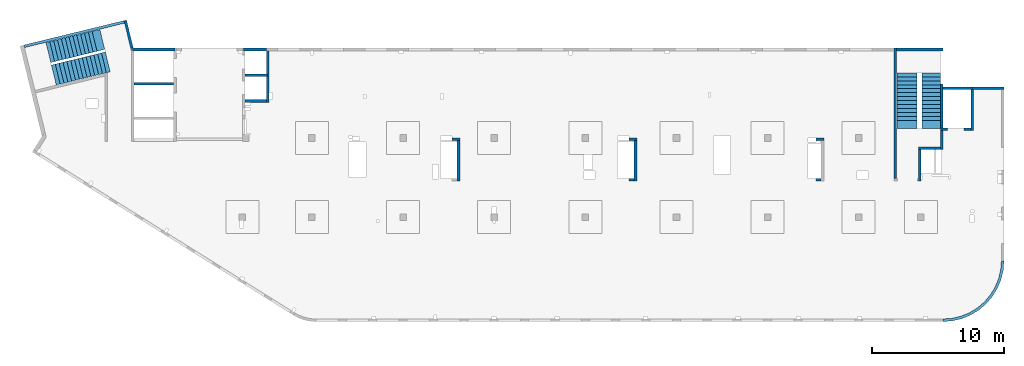
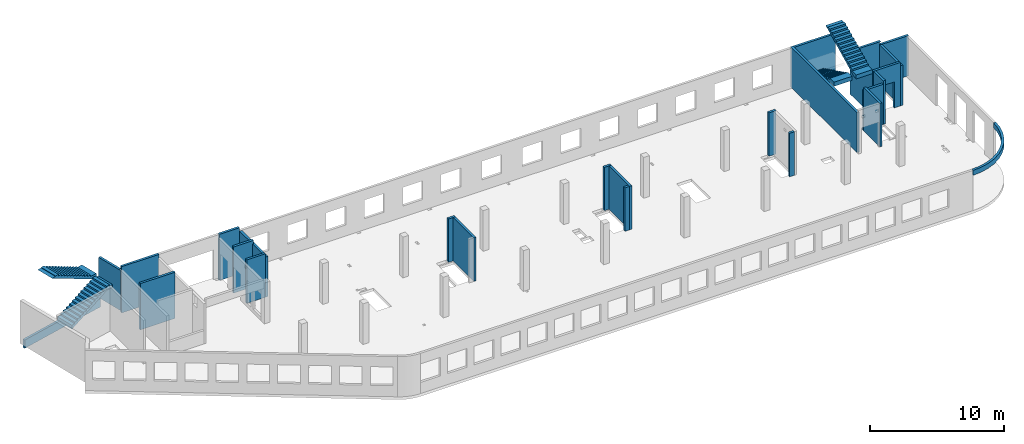
# One storey, part 3 of 6: 26 walls, 4 stairs, 1 opening.
"""IFC4 building model written with IfcOpenShell, lengths in millimetres."""

from ifc_helpers import new_model, entity, si_unit, converted_unit, derived_unit, direction, frame, origin, place, context, subcontext, project, spatial, indexed_curve, outline, extrude, polygons, material, type_object, element, save


model = new_model("IFC4")

# Units and contexts
model_context = context("Model", 3, precision=0.01, world=origin(), true_north=direction((6.12303176911189e-17, 1.0)))
plan_context = context("Plan", 3, precision=0.01, world=origin(), true_north=direction((6.12303176911189e-17, 1.0)))
body_context = subcontext(model_context, "Body", "Model", "MODEL_VIEW")
ifc_project = project(units=[si_unit("LENGTHUNIT", "METRE", prefix="MILLI"), si_unit("AREAUNIT", "SQUARE_METRE"), si_unit("VOLUMEUNIT", "CUBIC_METRE"), converted_unit("PLANEANGLEUNIT", "DEGREE", entity("IfcRatioMeasure", 0.0174532925199433), si_unit("PLANEANGLEUNIT", "RADIAN"), dimensions=[0, 0, 0, 0, 0, 0, 0]), si_unit("MASSUNIT", "GRAM", prefix="KILO"), derived_unit("MASSDENSITYUNIT", [(si_unit("MASSUNIT", "GRAM", prefix="KILO"), 1), (si_unit("LENGTHUNIT", "METRE"), -3)]), derived_unit("MOMENTOFINERTIAUNIT", [(si_unit("LENGTHUNIT", "METRE"), 4)]), si_unit("TIMEUNIT", "SECOND"), si_unit("FREQUENCYUNIT", "HERTZ"), si_unit("THERMODYNAMICTEMPERATUREUNIT", "DEGREE_CELSIUS"), derived_unit("THERMALTRANSMITTANCEUNIT", [(si_unit("MASSUNIT", "GRAM", prefix="KILO"), 1), (si_unit("THERMODYNAMICTEMPERATUREUNIT", "KELVIN"), -1), (si_unit("TIMEUNIT", "SECOND"), -3)]), derived_unit("VOLUMETRICFLOWRATEUNIT", [(si_unit("LENGTHUNIT", "METRE"), 3), (si_unit("TIMEUNIT", "SECOND"), -1)]), derived_unit("MASSFLOWRATEUNIT", [(si_unit("MASSUNIT", "GRAM", prefix="KILO"), 1), (si_unit("TIMEUNIT", "SECOND"), -1)]), derived_unit("ROTATIONALFREQUENCYUNIT", [(si_unit("TIMEUNIT", "SECOND"), -1)]), si_unit("ELECTRICCURRENTUNIT", "AMPERE"), si_unit("ELECTRICVOLTAGEUNIT", "VOLT"), si_unit("POWERUNIT", "WATT"), si_unit("FORCEUNIT", "NEWTON", prefix="KILO"), si_unit("ILLUMINANCEUNIT", "LUX"), si_unit("LUMINOUSFLUXUNIT", "LUMEN"), si_unit("LUMINOUSINTENSITYUNIT", "CANDELA"), derived_unit("USERDEFINED", [(si_unit("MASSUNIT", "GRAM", prefix="KILO"), -1), (si_unit("LENGTHUNIT", "METRE"), -2), (si_unit("TIMEUNIT", "SECOND"), 3), (si_unit("LUMINOUSFLUXUNIT", "LUMEN"), 1)]), derived_unit("LINEARVELOCITYUNIT", [(si_unit("LENGTHUNIT", "METRE"), 1), (si_unit("TIMEUNIT", "SECOND"), -1)]), si_unit("PRESSUREUNIT", "PASCAL"), derived_unit("USERDEFINED", [(si_unit("LENGTHUNIT", "METRE"), -2), (si_unit("MASSUNIT", "GRAM", prefix="KILO"), 1), (si_unit("TIMEUNIT", "SECOND"), -2)]), derived_unit("LINEARFORCEUNIT", [(si_unit("MASSUNIT", "GRAM", prefix="KILO"), 1), (si_unit("LENGTHUNIT", "METRE"), 1), (si_unit("TIMEUNIT", "SECOND"), -2), (si_unit("LENGTHUNIT", "METRE"), -1)]), derived_unit("PLANARFORCEUNIT", [(si_unit("MASSUNIT", "GRAM", prefix="KILO"), 1), (si_unit("LENGTHUNIT", "METRE"), 1), (si_unit("TIMEUNIT", "SECOND"), -2), (si_unit("LENGTHUNIT", "METRE"), -2)])], contexts=[model_context, plan_context])

# Site, building, storey
site_placement = place(None, origin())
site = spatial("IfcSite", under=ifc_project, at=site_placement, CompositionType="ELEMENT")
building_placement = place(site_placement, origin())
building = spatial("IfcBuilding", under=site, at=building_placement, CompositionType="ELEMENT")
storey_placement = place(building_placement, frame((0.0, 0.0, 12000.0)))
storey = spatial("IfcBuildingStorey", under=building, at=storey_placement, Name="04", CompositionType="ELEMENT", Elevation=12000.0)

# Walls
ifc_material_1 = material()
wall_type = type_object("IfcWallType", Name=":ADSK_ 25_200", PredefinedType="STANDARD")
wall_1_placement = place(storey_placement, frame((71070.0, 17470.0, -150.0)))
element("IfcWall", 1, at=wall_1_placement, inside=storey, type_object=wall_type, material=ifc_material_1, Name=":ADSK_ 25_200", ObjectType=":ADSK_ 25_200", PredefinedType="NOTDEFINED", context=body_context, shape_type="SweptSolid", body=[
    extrude(outline(indexed_curve([(2500.00000000001, -99.9999999999999), (2500.00000000001, 100.0), (99.9999999999943, 99.9999999999992), (99.9999999999949, -100.000000000001), (199.999999999998, -100.0), (2300.00000000001, -100.0), (2500.00000000001, -99.9999999999999)], self_intersect=False)), origin(), (0.0, 0.0, 1.0), 3650.0),
])
wall_2_placement = place(storey_placement, frame((71170.0, 17370.0, -150.0), z_axis=(0.0, 0.0, 1.0), x_axis=(0.0, -1.0, 0.0)))
element("IfcWall", 2, at=wall_2_placement, inside=storey, type_object=wall_type, material=ifc_material_1, Name=":ADSK_ 25_200", ObjectType=":ADSK_ 25_200", PredefinedType="NOTDEFINED", context=body_context, shape_type="SweptSolid", body=[
    extrude(outline(indexed_curve([(3100.0, 100.000000000003), (-2.79449581754433e-13, 100.000000000003), (2.79449581754433e-13, -100.000000000003), (3100.0, -100.000000000003), (3100.0, 100.000000000003)], self_intersect=False)), origin(), (0.0, 0.0, 1.0), 3650.0),
])

# Wall, opening
wall_3_placement = place(storey_placement, frame((71070.0, 14370.0, -150.0), z_axis=(0.0, 0.0, 1.0), x_axis=(-1.0, 0.0, 0.0)))
wall_3 = element("IfcWall", 3, at=wall_3_placement, inside=storey, type_object=wall_type, material=ifc_material_1, Name=":ADSK_ 25_200", ObjectType=":ADSK_ 25_200", PredefinedType="NOTDEFINED", context=body_context, shape_type="Tessellation", body=[
    polygons([(2299.99918212887, -100.000000000003, 3950.0), (2099.99918212887, -100.000000000001, 3950.0), (-2.4387927500343e-12, -100.000000000001, 3950.0), (-2.4387927500343e-12, -100.000000000001, 0.0), (529.999182128873, -100.000000000001, 0.0), (529.999182128864, -100.000000000001, 2369.99999999804), (1769.99918212887, -99.9999999999989, 2369.99999999804), (1769.99918212887, -100.000000000003, 0.0), (2099.99918212886, -100.000000000003, 0.0), (2099.99918212886, -100.000000000003, 49.9999999999973), (2299.99918212887, -100.000000000003, 49.9999999999973), (2299.99918212887, -100.000000000001, 3650.0), (-3.00376710535355e-12, 99.9999999999968, 3950.0), (2099.99918212887, 99.9999999999989, 3950.0), (2299.99918212887, 99.9999999999989, 3950.0), (2299.99918212887, 99.9999999999989, 3900.0), (2299.99918212887, 99.9999999999989, 49.9999999999973), (2099.99918212886, 99.9999999999989, 49.9999999999973), (2099.99918212886, 99.9999999999989, 0.0), (1769.99918212887, 99.9999999999989, 0.0), (1769.99918212887, 99.9999999999989, 2369.99999999804), (529.999182128872, 99.9999999999989, 2369.99999999804), (529.999182128872, 99.9999999999989, 0.0), (-3.00376710535355e-12, 99.9999999999968, 0.0), (-3.00376710535355e-12, 99.9999999999989, 3650.0)], [[[1, 2, 3, 4, 5, 6, 7, 8, 9, 10, 11, 12]], [[13, 14, 15, 16, 17, 18, 19, 20, 21, 22, 23, 24, 25]], [[4, 24, 23, 5]], [[3, 2, 1, 15, 14, 13]], [[4, 3, 13, 25, 24]], [[6, 22, 21, 7]], [[7, 21, 20, 8]], [[22, 6, 5, 23]], [[11, 10, 18, 17]], [[10, 9, 19, 18]], [[11, 17, 16, 15, 1, 12]], [[19, 9, 8, 20]]], closed=True),
])
opening_placement = place(wall_3_placement, frame((71070.0, 14370.0, 150.0), z_axis=(0.0, 0.0, 1.0), x_axis=(-1.0, 0.0, 0.0)))
element("IfcOpeningElement", 4, at=opening_placement, cuts=wall_3, Name=":ADSK_ 25_200", PredefinedType="OPENING", context=body_context, shape_type="SweptSolid", body=[
    extrude(outline(indexed_curve([(-619.999999999998, -1184.99999999902), (620.000000000006, -1184.99999999902), (620.000000000006, 1184.99999999902), (-619.999999999998, 1184.99999999902), (-619.999999999998, -1184.99999999902)], self_intersect=False)), frame((69920.0, 14570.0, 1035.0), z_axis=(0.0, -1.0, 0.0), x_axis=(-1.0, 0.0, 0.0)), (0.0, 0.0, 1.0), 400.000000001943),
])

# Walls
wall_4_placement = place(storey_placement, frame((68870.0, 14270.0, -150.0), z_axis=(0.0, 0.0, 1.0), x_axis=(0.0, -1.0, 0.0)))
element("IfcWall", 5, at=wall_4_placement, inside=storey, type_object=wall_type, material=ifc_material_1, Name=":ADSK_ 25_200", ObjectType=":ADSK_ 25_200", PredefinedType="NOTDEFINED", context=body_context, shape_type="SweptSolid", body=[
    extrude(outline(indexed_curve([(1439.99999999999, 100.000000000003), (0.0, 100.000000000003), (0.0, -100.000000000003), (1439.99999999999, -100.000000000003), (1439.99999999999, 100.000000000003)], self_intersect=False)), origin(), (0.0, 0.0, 1.0), 3950.0),
])
wall_5_placement = place(storey_placement, frame((68770.0, 12930.0, -150.0), z_axis=(0.0, 0.0, 1.0), x_axis=(-1.0, 0.0, 0.0)))
element("IfcWall", 6, at=wall_5_placement, inside=storey, type_object=wall_type, material=ifc_material_1, Name=":ADSK_ 25_200", ObjectType=":ADSK_ 25_200", PredefinedType="NOTDEFINED", context=body_context, shape_type="SweptSolid", body=[
    extrude(outline(indexed_curve([(1689.99999999997, 99.9999999999989), (-3.84449868389964e-13, 99.9999999999989), (3.84449868389964e-13, -99.9999999999989), (1689.99999999997, -99.9999999999989), (1689.99999999997, 99.9999999999989)], self_intersect=False)), origin(), (0.0, 0.0, 1.0), 3650.0),
])
wall_6_placement = place(storey_placement, frame((67180.0, 12830.0, -150.0), z_axis=(0.0, 0.0, 1.0), x_axis=(0.0, -1.0, 0.0)))
element("IfcWall", 7, at=wall_6_placement, inside=storey, type_object=wall_type, material=ifc_material_1, Name=":ADSK_ 25_200", ObjectType=":ADSK_ 25_200", PredefinedType="NOTDEFINED", context=body_context, shape_type="SweptSolid", body=[
    extrude(outline(indexed_curve([(2404.99999999995, 100.000000000003), (0.0, 100.000000000003), (0.0, -100.000000000003), (2404.99999999995, -100.000000000003), (2404.99999999995, 100.000000000003)], self_intersect=False)), origin(), (0.0, 0.0, 1.0), 3950.0),
])
wall_7_placement = place(storey_placement, frame((65330.0, 10625.0, -150.0), z_axis=(0.0, 0.0, 1.0), x_axis=(0.0, 1.0, 0.0)))
element("IfcWall", 8, at=wall_7_placement, inside=storey, type_object=wall_type, material=ifc_material_1, Name=":ADSK_ 25_200", ObjectType=":ADSK_ 25_200", PredefinedType="NOTDEFINED", context=body_context, shape_type="SweptSolid", body=[
    extrude(outline(indexed_curve([(9875.00063936713, 100.000000000003), (-1.71685740578866e-13, 100.000000000003), (1.71685740578866e-13, -100.000000000003), (9875.00063936713, -100.000000000004), (9875.00063936713, 100.000000000003)], self_intersect=False)), origin(), (0.0, 0.0, 1.0), 3650.0),
])
wall_8_placement = place(storey_placement, frame((68970.0, -100.0, 3050.0)))
element("IfcWall", 9, at=wall_8_placement, inside=storey, type_object=wall_type, material=ifc_material_1, Name=":ADSK_ 25_200", ObjectType=":ADSK_ 25_200", PredefinedType="NOTDEFINED", context=body_context, shape_type="SweptSolid", body=[
    extrude(outline(indexed_curve([(4399.99918212903, 4499.99918212888), (4345.82789081698, 3811.68766389508), (4184.64789385715, 3140.32465961517), (3920.42797770043, 2502.44135458057), (3559.67411357824, 1913.74455277455), (3111.26925889869, 1388.72992323025), (2586.25462935438, 940.325068550716), (1997.55782754836, 579.571204428538), (1359.67452251375, 315.351288271842), (688.311518233829, 154.171291312031), (3.46517481375486e-11, 100.0), (0.0, -100.0), (719.598411241839, -43.3663768070014), (1421.47792138871, 125.139985012801), (2088.35592749623, 401.369899590849), (2703.81167981284, 778.521669675706), (3252.69061513597, 1247.30856699292), (3721.47751245321, 1796.18750231603), (4098.6292825381, 2411.64325463263), (4374.85919711618, 3078.52126074015), (4543.365558936, 3780.40077088701), (4599.99918212903, 4499.99918212885), (4399.99918212903, 4499.99918212888)], self_intersect=False)), origin(), (0.0, 0.0, 1.0), 450.000000000002),
])
wall_9_placement = place(storey_placement, frame((17825.0, 20300.0, -150.0), z_axis=(0.0, 0.0, 1.0), x_axis=(0.0, -1.0, 0.0)))
element("IfcWall", 10, at=wall_9_placement, inside=storey, type_object=wall_type, material=ifc_material_1, Name=":ADSK_ 25_200", ObjectType=":ADSK_ 25_200", PredefinedType="NOTDEFINED", context=body_context, shape_type="SweptSolid", body=[
    extrude(outline(indexed_curve([(3900.00063936684, 99.9999999999989), (-1.66594915657375e-13, 99.9999999999989), (1.66594915657375e-13, -99.9999999999989), (3900.00063936684, -99.9999999999989), (3900.00063936684, 99.9999999999989)], self_intersect=False)), origin(), (0.0, 0.0, 1.0), 3650.0),
])
wall_10_placement = place(storey_placement, frame((17725.0, 16500.0, -150.0), z_axis=(0.0, 0.0, 1.0), x_axis=(-1.0, 0.0, 0.0)))
element("IfcWall", 11, at=wall_10_placement, inside=storey, type_object=wall_type, material=ifc_material_1, Name=":ADSK_ 25_200", ObjectType=":ADSK_ 25_200", PredefinedType="NOTDEFINED", context=body_context, shape_type="SweptSolid", body=[
    extrude(outline(indexed_curve([(1624.99999999999, 99.9999999999982), (-3.56011111002209e-13, 99.9999999999989), (3.56011111002209e-13, -99.9999999999989), (1624.99999999999, -99.9999999999996), (1624.99999999999, 99.9999999999982)], self_intersect=False)), origin(), (0.0, 0.0, 1.0), 3950.0),
])
wall_11_placement = place(storey_placement, frame((68870.0, 17780.0, -400.0), z_axis=(0.0, 0.0, 1.0), x_axis=(0.0, -1.0, 0.0)))
element("IfcWall", 12, at=wall_11_placement, inside=storey, type_object=wall_type, material=ifc_material_1, Name=":ADSK_ 25_200", ObjectType=":ADSK_ 25_200", PredefinedType="NOTDEFINED", context=body_context, shape_type="Tessellation", body=[
    polygons([(2.16573425859679e-12, -99.9999999999946, 0.0), (3310.0, -99.9999999999946, 0.0), (3310.0, -99.9999999999946, 299.999999999997), (3310.0, -99.9999999999946, 3900.0), (2.16573425859679e-12, -99.9999999999946, 3900.0), (3310.0, 100.000000000012, 0.0), (410.0, 100.000000000003, 0.0), (210.0, 100.000000000003, 0.0), (2.16573425859679e-12, 100.000000000012, 0.0), (2.16573425859679e-12, 100.000000000012, 3900.0), (3310.0, 100.000000000012, 3900.0)], [[[1, 2, 3, 4, 5]], [[6, 7, 8, 9, 10, 11]], [[2, 1, 9, 8, 7, 6]], [[9, 1, 5, 10]], [[2, 6, 11, 4, 3]], [[5, 4, 11, 10]]], closed=True),
])
wall_12_placement = place(storey_placement, frame((68970.0, 17470.0, -400.0)))
element("IfcWall", 13, at=wall_12_placement, inside=storey, type_object=wall_type, material=ifc_material_1, Name=":ADSK_ 25_200", ObjectType=":ADSK_ 25_200", PredefinedType="NOTDEFINED", context=body_context, shape_type="Tessellation", body=[
    polygons([(2199.99918212887, -100.000000000001, 4200.0), (2099.99918212888, -100.000000000001, 4200.0), (6.89939203009021e-12, -100.000000000001, 4200.0), (6.89939203009021e-12, -100.000000000001, 0.0), (2099.99918212889, -100.000000000001, 0.0), (2099.99918212889, -100.000000000001, 249.999999999999), (2199.99918212887, -100.000000000001, 249.999999999999), (2199.99918212887, -100.000000000001, 299.999999999997), (2099.99918212888, -100.000000000001, 299.999999999997), (2099.99918212889, -100.000000000001, 3900.0), (2099.99918212889, -100.000000000001, 4150.0), (2199.99918212887, -100.000000000001, 4150.0), (6.28061057235613e-12, 99.9999999999989, 4200.0), (2099.99918212888, 99.9999999999989, 4200.0), (2199.99918212887, 99.9999999999989, 4200.0), (2199.99918212887, 99.9999999999989, 4150.0), (2099.99918212889, 99.9999999999946, 4150.0), (2099.99918212889, 99.9999999999989, 3900.0), (2099.99918212888, 99.9999999999989, 299.999999999997), (2199.99918212887, 99.9999999999989, 299.999999999997), (2199.99918212887, 99.9999999999989, 249.999999999999), (2099.99918212889, 99.9999999999946, 249.999999999999), (2099.99918212889, 99.9999999999989, 0.0), (6.28061057235613e-12, 99.9999999999989, 0.0)], [[[1, 2, 3, 4, 5, 6, 7, 8, 9, 10, 11, 12]], [[13, 14, 15, 16, 17, 18, 19, 20, 21, 22, 23, 24]], [[4, 24, 23, 5]], [[3, 2, 1, 15, 14, 13]], [[20, 8, 7, 21]], [[9, 19, 18, 17, 11, 10]], [[15, 1, 12, 16]], [[3, 13, 24, 4]], [[9, 8, 20, 19]], [[6, 22, 21, 7]], [[22, 6, 5, 23]], [[11, 17, 16, 12]]], closed=True),
])
wall_13_placement = place(storey_placement, frame((65430.0, 20400.0, -400.0)))
element("IfcWall", 14, at=wall_13_placement, inside=storey, type_object=wall_type, material=ifc_material_1, Name=":ADSK_ 25_200", ObjectType=":ADSK_ 25_200", PredefinedType="NOTDEFINED", context=body_context, shape_type="SweptSolid", body=[
    extrude(outline(indexed_curve([(3539.99999999995, 99.9999999999989), (-3.67073603151997e-13, 99.9999999999989), (3.67073603151997e-13, -99.9999999999989), (3539.99999999995, -99.9999999999989), (3539.99999999995, 99.9999999999989)], self_intersect=False)), origin(), (0.0, 0.0, 1.0), 3900.0),
])
wall_14_placement = place(storey_placement, frame((16000.0, 20400.0, -400.0)))
element("IfcWall", 15, at=wall_14_placement, inside=storey, type_object=wall_type, material=ifc_material_1, Name=":ADSK_ 25_200", ObjectType=":ADSK_ 25_200", PredefinedType="NOTDEFINED", context=body_context, shape_type="SweptSolid", body=[
    extrude(outline(indexed_curve([(1724.99999999999, -100.000000000003), (1724.99999999999, 99.9999999999992), (99.9999999999987, 99.9999999999992), (-2.66551908750372e-13, 99.9999999999989), (2.66551908750383e-13, -100.000000000003), (99.9999999999992, -100.000000000003), (1724.99999999999, -100.000000000003)], self_intersect=False)), origin(), (0.0, 0.0, 1.0), 4200.0),
])
wall_15_placement = place(storey_placement, frame((16100.0, 18450.0, -400.0)))
element("IfcWall", 16, at=wall_15_placement, inside=storey, type_object=wall_type, material=ifc_material_1, Name=":ADSK_ 25_200", ObjectType=":ADSK_ 25_200", PredefinedType="NOTDEFINED", context=body_context, shape_type="SweptSolid", body=[
    extrude(outline(indexed_curve([(1725.0, 99.9999999999992), (-2.66551908750371e-13, 99.9999999999989), (2.66551908750371e-13, -99.9999999999989), (1725.0, -99.9999999999987), (1725.0, 99.9999999999992)], self_intersect=False)), origin(), (0.0, 0.0, 1.0), 4200.0),
])
wall_16_placement = place(storey_placement, frame((7500.0, 20400.0, -400.0)))
element("IfcWall", 17, at=wall_16_placement, inside=storey, type_object=wall_type, material=ifc_material_1, Name=":ADSK_ 25_200", ObjectType=":ADSK_ 25_200", PredefinedType="NOTDEFINED", context=body_context, shape_type="SweptSolid", body=[
    extrude(outline(indexed_curve([(3300.0, -100.000000000002), (3300.0, 99.9999999999998), (3200.0, 99.9999999999995), (99.9999999999997, 99.9999999999992), (99.9999999999992, -100.000000000003), (3300.0, -100.000000000002)], self_intersect=False)), origin(), (0.0, 0.0, 1.0), 4200.0),
])
wall_17_placement = place(storey_placement, frame((7700.0, 17800.0, -400.0)))
element("IfcWall", 18, at=wall_17_placement, inside=storey, type_object=wall_type, material=ifc_material_1, Name=":ADSK_ 25_200", ObjectType=":ADSK_ 25_200", PredefinedType="NOTDEFINED", context=body_context, shape_type="SweptSolid", body=[
    extrude(outline(indexed_curve([(3000.0, 99.9999999999989), (-2.88764567812902e-13, 99.9999999999989), (2.88764567812902e-13, -99.9999999999989), (3000.0, -99.9999999999989), (3000.0, 99.9999999999989)], self_intersect=False)), origin(), (0.0, 0.0, 1.0), 4200.0),
])
wall_18_placement = place(storey_placement, frame((59330.0, 13600.0, -150.0)))
element("IfcWall", 19, at=wall_18_placement, inside=storey, type_object=wall_type, material=ifc_material_1, Name=":ADSK_ 25_200", ObjectType=":ADSK_ 25_200", PredefinedType="NOTDEFINED", context=body_context, shape_type="SweptSolid", body=[
    extrude(outline(indexed_curve([(599.999999999993, 99.9999999999989), (-3.60955709766131e-13, 99.9999999999989), (3.60955709766131e-13, -99.9999999999989), (599.999999999994, -99.9999999999989), (599.999999999993, 99.9999999999989)], self_intersect=False)), origin(), (0.0, 0.0, 1.0), 3950.0),
])
wall_19_placement = place(storey_placement, frame((59730.0, 10525.0, -150.0), z_axis=(0.0, 0.0, 1.0), x_axis=(-1.0, 0.0, 0.0)))
element("IfcWall", 20, at=wall_19_placement, inside=storey, type_object=wall_type, material=ifc_material_1, Name=":ADSK_ 25_200", ObjectType=":ADSK_ 25_200", PredefinedType="NOTDEFINED", context=body_context, shape_type="SweptSolid", body=[
    extrude(outline(indexed_curve([(399.999999999987, 99.9999999999982), (-3.60955709766136e-13, 99.9999999999989), (3.60955709766136e-13, -99.9999999999989), (399.999999999987, -99.9999999999996), (399.999999999987, 99.9999999999982)], self_intersect=False)), origin(), (0.0, 0.0, 1.0), 3950.0),
])
wall_20_placement = place(storey_placement, frame((45170.0, 13600.0, -150.0)))
element("IfcWall", 21, at=wall_20_placement, inside=storey, type_object=wall_type, material=ifc_material_1, Name=":ADSK_ 25_200", ObjectType=":ADSK_ 25_200", PredefinedType="NOTDEFINED", context=body_context, shape_type="SweptSolid", body=[
    extrude(outline(indexed_curve([(599.999999999993, 99.9999999999989), (-3.60955709766131e-13, 99.9999999999989), (3.60955709766131e-13, -99.9999999999989), (599.999999999994, -99.9999999999989), (599.999999999993, 99.9999999999989)], self_intersect=False)), origin(), (0.0, 0.0, 1.0), 3950.0),
])
wall_21_placement = place(storey_placement, frame((45670.0, 13500.0, -150.0), z_axis=(0.0, 0.0, 1.0), x_axis=(0.0, -1.0, 0.0)))
element("IfcWall", 22, at=wall_21_placement, inside=storey, type_object=wall_type, material=ifc_material_1, Name=":ADSK_ 25_200", ObjectType=":ADSK_ 25_200", PredefinedType="NOTDEFINED", context=body_context, shape_type="SweptSolid", body=[
    extrude(outline(indexed_curve([(3074.99985044015, 100.000000000003), (-2.64517173435081e-13, 100.000000000003), (2.64517173435081e-13, -100.000000000003), (3074.99985044015, -100.000000000004), (3074.99985044015, 100.000000000003)], self_intersect=False)), origin(), (0.0, 0.0, 1.0), 3950.0),
])
wall_22_placement = place(storey_placement, frame((45570.0, 10525.0, -150.0), z_axis=(0.0, 0.0, 1.0), x_axis=(-1.0, 0.0, 0.0)))
element("IfcWall", 23, at=wall_22_placement, inside=storey, type_object=wall_type, material=ifc_material_1, Name=":ADSK_ 25_200", ObjectType=":ADSK_ 25_200", PredefinedType="NOTDEFINED", context=body_context, shape_type="SweptSolid", body=[
    extrude(outline(indexed_curve([(399.999999999995, 99.9999999999982), (-3.60955709766131e-13, 99.9999999999989), (3.60955709766131e-13, -99.9999999999989), (399.999999999996, -99.9999999999996), (399.999999999995, 99.9999999999982)], self_intersect=False)), origin(), (0.0, 0.0, 1.0), 3950.0),
])
wall_23_placement = place(storey_placement, frame((31770.0, 13600.0, -150.0)))
element("IfcWall", 24, at=wall_23_placement, inside=storey, type_object=wall_type, material=ifc_material_1, Name=":ADSK_ 25_200", ObjectType=":ADSK_ 25_200", PredefinedType="NOTDEFINED", context=body_context, shape_type="SweptSolid", body=[
    extrude(outline(indexed_curve([(600.000000000002, 99.9999999999989), (-3.60955709766126e-13, 99.9999999999989), (3.60955709766126e-13, -99.9999999999989), (600.000000000003, -99.9999999999989), (600.000000000002, 99.9999999999989)], self_intersect=False)), origin(), (0.0, 0.0, 1.0), 3950.0),
])
wall_24_placement = place(storey_placement, frame((32270.0, 13500.0, -150.0), z_axis=(0.0, 0.0, 1.0), x_axis=(0.0, -1.0, 0.0)))
element("IfcWall", 25, at=wall_24_placement, inside=storey, type_object=wall_type, material=ifc_material_1, Name=":ADSK_ 25_200", ObjectType=":ADSK_ 25_200", PredefinedType="NOTDEFINED", context=body_context, shape_type="SweptSolid", body=[
    extrude(outline(indexed_curve([(3074.99985044025, 99.9999999999987), (-1.32258586717531e-13, 99.9999999999989), (1.32258586717531e-13, -99.9999999999989), (3074.99985044025, -99.9999999999992), (3074.99985044025, 99.9999999999987)], self_intersect=False)), origin(), (0.0, 0.0, 1.0), 3950.0),
])
wall_25_placement = place(storey_placement, frame((7033.44, 22609.75, -150.0), z_axis=(0.0, 0.0, 1.0), x_axis=(0.236826092990328, -0.971552058141475, 0.0)))
element("IfcWall", 26, at=wall_25_placement, inside=storey, type_object=wall_type, material=ifc_material_1, Name=":ADSK_ 25_200", ObjectType=":ADSK_ 25_200", PredefinedType="NOTDEFINED", context=body_context, shape_type="SweptSolid", body=[
    extrude(outline(indexed_curve([(2380.28371765147, -99.9999999999991), (2354.53748529952, -93.7240834744376), (2160.22707367122, -46.3588648763715), (2195.90359543113, 99.9999999999994), (-1.39588340886121e-13, 99.9999999999987), (-1.1420864254319e-13, -99.9999999999997), (199.999999999995, -100.0), (2380.28371765147, -99.9999999999991)], self_intersect=False)), origin(), (0.0, 0.0, 1.0), 3650.0),
])
wall_26_placement = place(storey_placement, frame((-618.13, 20641.67, -900.0), z_axis=(0.0, 0.0, 1.0), x_axis=(0.971552058141473, 0.236826092990337, 0.0)))
element("IfcWall", 27, at=wall_26_placement, inside=storey, type_object=wall_type, material=ifc_material_1, Name=":ADSK_ 25_200", ObjectType=":ADSK_ 25_200", PredefinedType="NOTDEFINED", context=body_context, shape_type="SweptSolid", body=[
    extrude(outline(indexed_curve([(7799.99206966276, 100.000000000001), (6.34492458573277e-14, 100.0), (-6.34492458573277e-14, -100.0), (7799.99206966276, -99.9999999999989), (7799.99206966276, 100.000000000001)], self_intersect=False)), origin(), (0.0, 0.0, 1.0), 750.000000000003),
])

# Stairs
ifc_material_2 = material()
stair_type_1 = type_object("IfcStairType", Name="20: 15", PredefinedType="HALF_TURN_STAIR")
placement = place(storey_placement, origin())
element("IfcStair", 28, at=placement, inside=storey, type_object=stair_type_1, material=ifc_material_2, Name="20: 15", ObjectType="20: 15", PredefinedType="HALF_TURN_STAIR", context=body_context, shape_type="SweptSolid", body=[
    extrude(outline(indexed_curve([(843.870967741944, -2179.17507067742), (1213.87096774194, -2179.17507067742), (1213.87096774195, -1871.96147517747), (-906.129032258053, 2368.03852482254), (-906.129032258053, 2020.82492932259), (-956.129032258054, 2020.82492932259), (-956.129032258054, 1720.82492932259), (-806.129032258056, 1720.82492932259), (-806.129032258056, 1420.82492932259), (-656.129032258055, 1420.82492932259), (-656.129032258055, 1120.82492932259), (-506.129032258057, 1120.82492932259), (-506.129032258057, 820.824929322588), (-356.129032258056, 820.824929322588), (-356.129032258056, 520.824929322586), (-206.129032258056, 520.824929322586), (-206.129032258056, 220.824929322585), (-56.1290322580552, 220.824929322585), (-56.1290322580552, -79.1750706774158), (93.8709677419453, -79.1750706774158), (93.8709677419453, -379.175070677417), (243.870967741946, -379.175070677417), (243.870967741946, -679.175070677418), (393.870967741944, -679.175070677418), (393.870967741944, -979.175070677419), (543.870967741945, -979.175070677419), (543.870967741945, -1279.17507067742), (693.870967741945, -1279.17507067742), (693.870967741945, -1579.17507067742), (843.870967741944, -1579.17507067742), (843.870967741944, -2179.17507067742)], self_intersect=False)), frame((67360.0, 16609.17, 4713.87), z_axis=(1.0, 0.0, 0.0), x_axis=(0.0, 0.0, -1.0)), (0.0, 0.0, 1.0), 1390.0),
])
stair_type_2 = type_object("IfcStairType", Name="25: 22", PredefinedType="HALF_TURN_STAIR")
element("IfcStair", 29, at=placement, inside=storey, type_object=stair_type_2, material=ifc_material_2, Name="25: 22", ObjectType="25: 22", PredefinedType="HALF_TURN_STAIR", context=body_context, shape_type="SweptSolid", body=[
    extrude(outline(indexed_curve([(-1961.8142397, -852.000000000003), (-1961.8142397, -1202.0), (-1914.60064420005, -1202.00000000001), (1645.39935579996, 577.999999999996), (2238.18576029999, 577.999999999996), (2238.18576029999, 947.999999999997), (1638.18576030001, 947.999999999997), (1638.18576030001, 797.999999999998), (1338.18576030001, 797.999999999998), (1338.18576030001, 647.999999999998), (1038.18576030001, 647.999999999998), (1038.18576030001, 497.999999999997), (738.185760300006, 497.999999999997), (738.185760300006, 347.999999999997), (438.185760300005, 347.999999999997), (438.185760300005, 197.999999999996), (138.185760300003, 197.999999999996), (138.185760300003, 47.9999999999977), (-161.814239699998, 47.9999999999977), (-161.814239699998, -102.000000000003), (-461.814239699999, -102.000000000003), (-461.814239699999, -252.000000000003), (-761.8142397, -252.000000000003), (-761.8142397, -402.000000000002), (-1061.8142397, -402.000000000002), (-1061.8142397, -552.000000000002), (-1361.8142397, -552.000000000002), (-1361.8142397, -702.000000000003), (-1661.8142397, -702.000000000003), (-1661.8142397, -852.000000000003), (-1961.8142397, -852.000000000003)], self_intersect=False)), frame((65450.0, 16668.18, 2922.0), z_axis=(-1.0, 0.0, 0.0), x_axis=(0.0, -1.0, 0.0)), (0.0, 0.0, -1.0), 1550.0),
])
stair_type_3 = type_object("IfcStairType", Name="32: 3", PredefinedType="HALF_TURN_STAIR")
element("IfcStair", 30, at=placement, inside=storey, type_object=stair_type_3, material=ifc_material_2, Name="32: 3", ObjectType="32: 3", PredefinedType="HALF_TURN_STAIR", context=body_context, shape_type="SweptSolid", body=[
    extrude(outline(indexed_curve([(872.000000000003, -2240.93152968505), (1242.0, -2240.93152968505), (1242.0, -1934.66369491541), (-878.000000000008, 2305.33630508466), (-878.00000000001, 1958.12270958467), (-927.999999999994, 1958.12270958467), (-927.999999999993, 1658.12270958467), (-777.999999999993, 1658.12270958467), (-777.999999999994, 1358.12270958466), (-627.999999999993, 1358.12270958466), (-627.999999999992, 1058.12270958466), (-477.999999999994, 1058.12270958466), (-477.999999999993, 758.122709584654), (-327.999999999993, 758.122709584654), (-327.999999999994, 458.12270958465), (-177.999999999993, 458.12270958465), (-177.999999999995, 158.122709584646), (-27.9999999999941, 158.122709584645), (-27.9999999999954, -141.877290415355), (122.000000000005, -141.877290415355), (122.000000000006, -441.877290415358), (272.000000000004, -441.877290415359), (272.000000000005, -741.877290415362), (422.000000000006, -741.877290415362), (422.000000000004, -1041.87729041536), (572.000000000003, -1041.87729041537), (572.000000000004, -1341.87729041537), (722.000000000004, -1341.87729041537), (722.000000000003, -1641.87729041537), (872.000000000003, -1641.87729041537), (872.000000000003, -2240.93152968505)], self_intersect=False)), frame((3302.28, 19878.41, 4742.0), z_axis=(-0.236826092990341, 0.971552058141472, 0.0), x_axis=(0.0, 0.0, -1.0)), (0.0, 0.0, 1.0), 1550.00000000006),
])
stair_type_4 = type_object("IfcStairType", Name="37: 34", PredefinedType="HALF_TURN_STAIR")
element("IfcStair", 31, at=placement, inside=storey, type_object=stair_type_4, material=ifc_material_2, Name="37: 34", ObjectType="37: 34", PredefinedType="HALF_TURN_STAIR", context=body_context, shape_type="SweptSolid", body=[
    extrude(outline(indexed_curve([(-2082.95035407268, -903.75), (-2082.95035407268, -1253.75), (-2035.73675857273, -1253.75), (1524.26324142725, 526.249999999975), (2117.04171559009, 526.249999999973), (2117.0417155901, 776.249999999969), (1817.04964592736, 776.249999999971), (1817.04964592736, 896.250000000006), (1517.04964592735, 896.250000000006), (1517.04964592735, 746.250000000006), (1217.04964592735, 746.250000000006), (1217.04964592735, 596.250000000005), (917.049645927347, 596.250000000005), (917.049645927346, 446.250000000005), (617.049645927341, 446.250000000005), (617.049645927341, 296.250000000004), (317.049645927337, 296.250000000004), (317.049645927336, 146.250000000003), (17.0496459273321, 146.250000000003), (17.049645927331, -3.74999999999711), (-282.950354072671, -3.74999999999711), (-282.950354072672, -153.749999999998), (-582.950354072675, -153.749999999998), (-582.950354072676, -303.749999999998), (-882.950354072678, -303.749999999998), (-882.950354072679, -453.749999999999), (-1182.95035407268, -453.749999999999), (-1182.95035407268, -603.749999999999), (-1482.95035407268, -603.749999999999), (-1482.95035407268, -753.75), (-1782.95035407268, -753.75), (-1782.95035407268, -903.75), (-2082.95035407268, -903.75)], self_intersect=False)), frame((3838.0, 18207.76, 2973.75), z_axis=(0.236826092990333, -0.971552058141474, 0.0), x_axis=(0.971552058141474, 0.236826092990333, 0.0)), (0.0, 0.0, -1.0), 1550.0),
])

save(model, "model.ifc")
